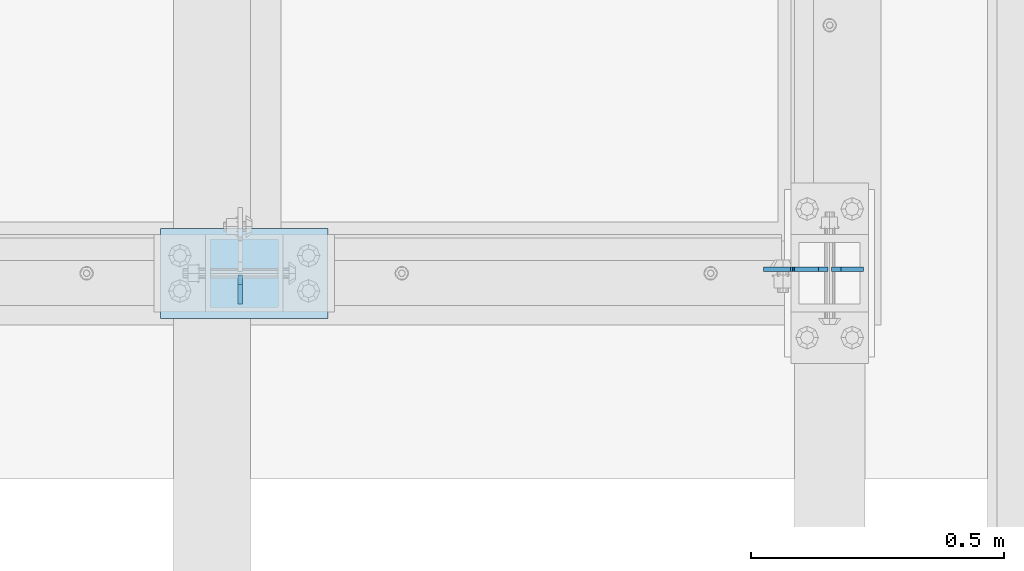
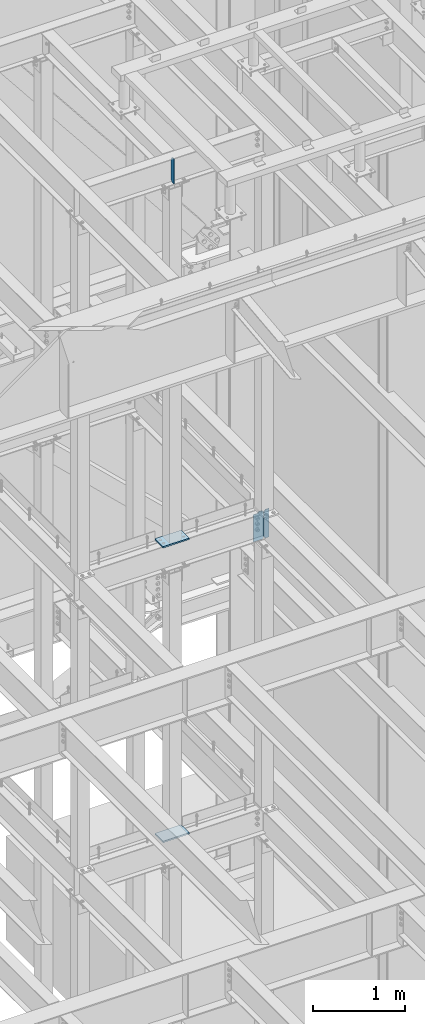
# One storey, part 1079 of 1179: 5 plates, 4 elements without a shape of their own.
"""IFC2X3 building model written with IfcOpenShell, lengths in millimetres."""

from ifc_helpers import new_model, si_unit, frame, origin_with_axes, place, context, subcontext, project, spatial, faceted_brep, material, type_object, element, aggregate, save


model = new_model("IFC2X3")

# Units and contexts
model_context = context("Model", 3, precision=1e-05, world=origin_with_axes())
body_context = subcontext(model_context, "Body", "Model", "MODEL_VIEW")
ifc_project = project(units=[si_unit("LENGTHUNIT", "METRE", prefix="MILLI"), si_unit("AREAUNIT", "SQUARE_METRE"), si_unit("VOLUMEUNIT", "CUBIC_METRE"), si_unit("MASSUNIT", "GRAM", prefix="KILO"), si_unit("TIMEUNIT", "SECOND"), si_unit("PLANEANGLEUNIT", "RADIAN"), si_unit("SOLIDANGLEUNIT", "STERADIAN"), si_unit("THERMODYNAMICTEMPERATUREUNIT", "DEGREE_CELSIUS"), si_unit("LUMINOUSINTENSITYUNIT", "LUMEN")], contexts=[model_context])

# Site, building, storey
site_placement = place(None, origin_with_axes())
site = spatial("IfcSite", under=ifc_project, at=site_placement, CompositionType="ELEMENT")
building_placement = place(site_placement, origin_with_axes())
building = spatial("IfcBuilding", under=site, at=building_placement, Name="Undefined", CompositionType="ELEMENT")
storey_placement = place(building_placement, origin_with_axes())
storey = spatial("IfcBuildingStorey", under=building, at=storey_placement, Name="Undefined", CompositionType="ELEMENT", Elevation=0.0)

# Assembly, plate
assembly_1_placement = place(storey_placement, origin_with_axes())
assembly_1 = element("IfcElementAssembly", 1, at=assembly_1_placement, inside=storey, Name="BEAM", AssemblyPlace="NOTDEFINED", PredefinedType="RIGID_FRAME")
ifc_material = material(Name="STEEL/A36")
plate_type_1 = type_object("IfcPlateType", PredefinedType="NOTDEFINED")
plate_1_placement = place(assembly_1_placement, frame((14182.725, 36647.4379999161, 7623.175), z_axis=(0.0, 0.0, 1.0), x_axis=(-1.0, 0.0, 0.0)))
plate_1 = element("IfcPlate", 2, at=plate_1_placement, type_object=plate_type_1, material=ifc_material, Name="PLATE", context=body_context, shape_type="Brep", body=[
    faceted_brep([(66.6749998164378, -4.76249999999709, 377.825), (66.6749999434469, -4.76249999999709, 371.474999553748), (66.6749999434469, 4.76249999999709, 371.474999553748), (66.6749998164378, 4.76249999999709, 377.825), (67.641729938794, -4.76249999999709, 366.614920114053), (67.641729938794, 4.76249999999709, 366.614920114053), (70.394743855788, -4.76249999999709, 362.494743732281), (70.394743855788, 4.76249999999709, 362.494743732281), (74.5149202922948, -4.76249999999709, 359.741729897201), (74.5149202922948, 4.76249999999709, 359.741729897201), (79.3749997512095, -4.76249999999709, 358.774999998475), (79.3749997512095, 4.76249999999709, 358.774999998475), (127.000000004868, -4.76249999999709, 358.774999992755), (127.0, 4.76249999999709, 358.774999992755), (0.0, -4.76249999999709, 358.775000762939), (19.0499992370605, -4.76249999999709, 377.825), (19.0499992370605, 4.76249999999709, 377.825), (0.0, 4.76249999999709, 358.775000762939), (0.0, -4.76250000000073, 19.0499992370605), (0.0, 4.76250000000073, 19.0499992370605), (19.0499992370605, -4.76250000000073, 0.0), (19.0499992370605, 4.76250000000073, 0.0), (127.0, -4.76250000000073, 0.0), (127.0, 4.76250000000073, 0.0)], [[[0, 1, 2, 3]], [[4, 5, 2, 1]], [[6, 7, 5, 4]], [[8, 9, 7, 6]], [[10, 11, 9, 8]], [[12, 13, 11, 10]], [[14, 15, 16, 17]], [[18, 14, 17, 19]], [[20, 18, 19, 21]], [[22, 20, 21, 23]], [[8, 6, 4, 1, 0, 15, 14, 18, 20, 22, 12, 10]], [[16, 15, 0, 3]], [[23, 21, 19, 17, 16, 3, 2, 5, 7, 9, 11, 13]], [[22, 23, 13, 12]]]),
])

assembly_2_placement = place(storey_placement, origin_with_axes())
assembly_2 = element("IfcElementAssembly", 3, at=assembly_2_placement, inside=storey, Name="BEAM", AssemblyPlace="NOTDEFINED", PredefinedType="RIGID_FRAME")
plate_type_2 = type_object("IfcPlateType", PredefinedType="NOTDEFINED")
plate_2_placement = place(assembly_2_placement, frame((13022.2620000839, 36636.325, 12779.375), z_axis=(0.0, 0.0, 1.0), x_axis=(0.0, -1.0, 0.0)))
plate_2 = element("IfcPlate", 4, at=plate_2_placement, type_object=plate_type_2, material=ifc_material, Name="PLATE", context=body_context, shape_type="Brep", body=[
    faceted_brep([(0.0, -4.76250000000073, 19.0499992370605), (0.0, -4.76250000000073, 311.150012969971), (0.0, 4.76250000000073, 311.150012969971), (0.0, 4.76250000000073, 19.0499992370605), (19.0499992370605, -4.76250000000073, 330.200012207031), (19.0499992370605, 4.76250000000073, 330.200012207031), (57.1500015258789, -4.76250000000073, 330.200012207031), (57.1500015258789, 4.76250000000073, 330.200012207031), (57.1500015258789, -4.76250000000073, 0.0), (57.1500015258789, 4.76250000000073, 0.0), (19.0499992370605, -4.76250000000073, 0.0), (19.0499992370605, 4.76250000000073, 0.0)], [[[0, 1, 2, 3]], [[1, 4, 5, 2]], [[4, 6, 7, 5]], [[6, 8, 9, 7]], [[8, 10, 11, 9]], [[10, 0, 3, 11]], [[5, 7, 9, 11, 3, 2]], [[10, 8, 6, 4, 1, 0]]]),
])
aggregate(assembly_2, [plate_2])

assembly_3_placement = place(storey_placement, origin_with_axes())
assembly_3 = element("IfcElementAssembly", 5, at=assembly_3_placement, inside=storey, Name="COLUMN", AssemblyPlace="NOTDEFINED", PredefinedType="RIGID_FRAME")
plate_type_3 = type_object("IfcPlateType", PredefinedType="NOTDEFINED")
plate_3_placement = place(assembly_3_placement, frame((12865.1, 36728.4, 4111.625), z_axis=(1.0, 0.0, 0.0), x_axis=(0.0, -1.0, 0.0)))
plate_3 = element("IfcPlate", 6, at=plate_3_placement, type_object=plate_type_3, material=ifc_material, Name="PLATE", context=body_context, shape_type="Brep", body=[
    faceted_brep([(0.0, -9.52499999999964, 0.0), (0.0, -9.52499999999964, 330.200012207031), (0.0, 9.52499999999964, 330.200012207031), (0.0, 9.52499999999964, 0.0), (177.800003051758, -9.52499999999964, 330.200012207031), (177.800003051758, 9.52499999999964, 330.200012207031), (177.800003051758, -9.52499999999964, 0.0), (177.800003051758, 9.52499999999964, 0.0)], [[[0, 1, 2, 3]], [[1, 4, 5, 2]], [[4, 6, 7, 5]], [[6, 0, 3, 7]], [[5, 7, 3, 2]], [[6, 4, 1, 0]]]),
])
aggregate(assembly_3, [plate_3])

assembly_4_placement = place(storey_placement, origin_with_axes())
assembly_4 = element("IfcElementAssembly", 7, at=assembly_4_placement, inside=storey, Name="COLUMN", AssemblyPlace="NOTDEFINED", PredefinedType="RIGID_FRAME")
plate_4_placement = place(assembly_4_placement, frame((12865.1, 36728.4, 8023.225), z_axis=(1.0, 0.0, 0.0), x_axis=(0.0, -1.0, 0.0)))
plate_4 = element("IfcPlate", 8, at=plate_4_placement, type_object=plate_type_3, material=ifc_material, Name="PLATE", context=body_context, shape_type="Brep", body=[
    faceted_brep([(0.0, -9.52499999999964, 0.0), (0.0, -9.52499999999964, 330.200012207031), (0.0, 9.52499999999964, 330.200012207031), (0.0, 9.52499999999964, 0.0), (177.800003051758, -9.52499999999964, 330.200012207031), (177.800003051758, 9.52499999999964, 330.200012207031), (177.800003051758, -9.52499999999964, 0.0), (177.800003051758, 9.52499999999964, 0.0)], [[[0, 1, 2, 3]], [[1, 4, 5, 2]], [[4, 6, 7, 5]], [[6, 0, 3, 7]], [[5, 7, 3, 2]], [[6, 4, 1, 0]]]),
])
aggregate(assembly_4, [plate_4])

# Plate
plate_type_4 = type_object("IfcPlateType", PredefinedType="NOTDEFINED")
plate_5_placement = place(assembly_1_placement, frame((14189.075, 36647.4379999161, 7623.175), z_axis=(0.0, 0.0, 1.0), x_axis=(1.0, 0.0, 0.0)))
plate_5 = element("IfcPlate", 9, at=plate_5_placement, type_object=plate_type_4, material=ifc_material, Name="PLATE", context=body_context, shape_type="Brep", body=[
    faceted_brep([(0.0, -4.76250000000073, 19.0499992370605), (0.0, -4.76249999999709, 358.775000762939), (0.0, 4.76249999999709, 358.775000762939), (0.0, 4.76250000000073, 19.0499992370605), (19.0499992370605, -4.76249999999709, 377.825), (19.0499992370605, 4.76249999999709, 377.825), (63.5, -4.76250000000073, 377.825012207031), (63.5, 4.76250000000073, 377.825012207031), (63.5, -4.76250000000073, 0.0), (63.5, 4.76250000000073, 0.0), (19.0499992370605, -4.76250000000073, 0.0), (19.0499992370605, 4.76250000000073, 0.0)], [[[0, 1, 2, 3]], [[1, 4, 5, 2]], [[4, 6, 7, 5]], [[6, 8, 9, 7]], [[8, 10, 11, 9]], [[10, 0, 3, 11]], [[5, 7, 9, 11, 3, 2]], [[10, 8, 6, 4, 1, 0]]]),
])

aggregate(assembly_1, [plate_5, plate_1])

save(model, "model.ifc")
